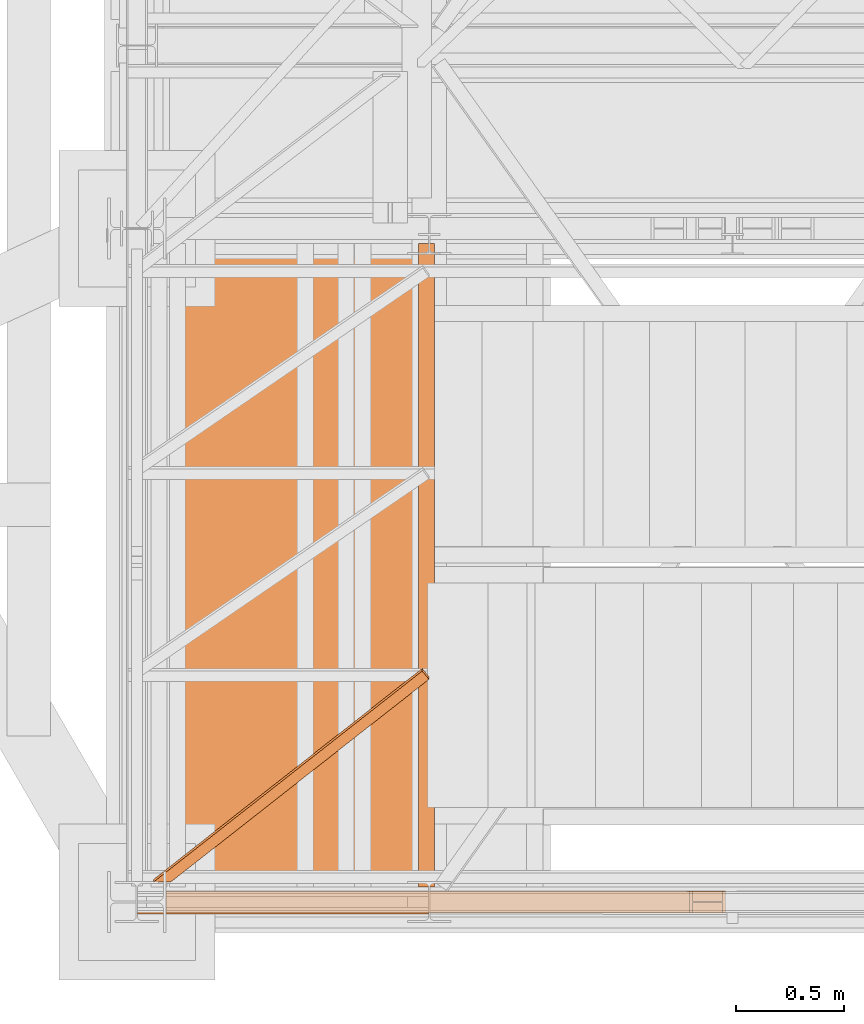
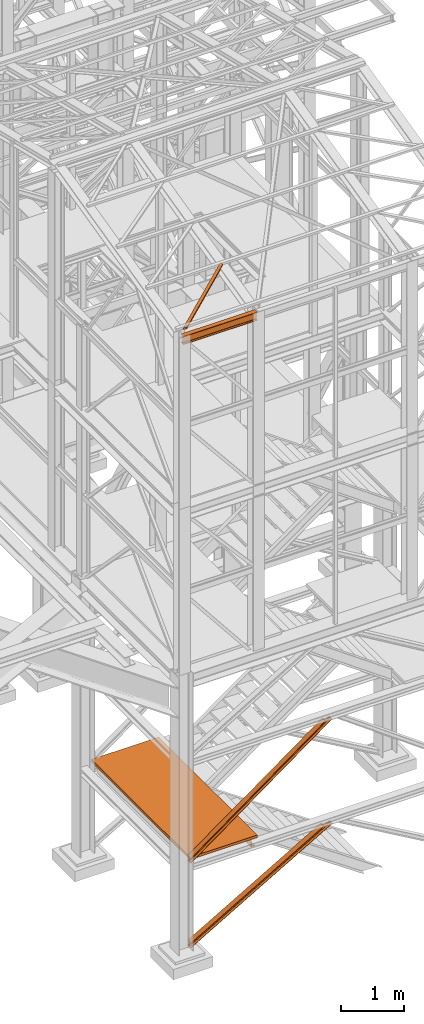
# One storey, part 8 of 208: 6 proxies.
"""IFC2X3 building model written with IfcOpenShell, lengths in millimetres."""

from ifc_helpers import new_model, entity, si_unit, converted_unit, frame, origin, origin_with_axes, place, context, subcontext, project, spatial, faceted_brep, element, save


model = new_model("IFC2X3")

# Units and contexts
model_context = context("Model", 3, precision=1e-05, world=origin())
plan_context = context("Plan", 3, precision=1e-05, world=origin())
body_context = subcontext(model_context, "Body", "Model", "MODEL_VIEW")
ifc_project = project(units=[si_unit("LENGTHUNIT", "METRE", prefix="MILLI"), converted_unit("PLANEANGLEUNIT", "DEGREE", entity("IfcPlaneAngleMeasure", 0.0174532925199433), si_unit("PLANEANGLEUNIT", "RADIAN"), dimensions=[0, 0, 0, 0, 0, 0, 0]), si_unit("AREAUNIT", "SQUARE_METRE"), si_unit("VOLUMEUNIT", "CUBIC_METRE")], contexts=[model_context, plan_context])

# Building, storey
building_placement = place(None, origin())
building = spatial("IfcBuilding", under=ifc_project, at=building_placement, CompositionType="COMPLEX")
storey_placement = place(building_placement, origin_with_axes())
storey = spatial("IfcBuildingStorey", under=building, at=storey_placement, Name="Geschoss", CompositionType="ELEMENT")

# Proxies
proxy_1_placement = place(storey_placement, frame((2498.108527679629, -25102.57439001986, 1399.989998075481), z_axis=(0.0, 0.0, 1.0), x_axis=(1.0, 0.0, 0.0)))
element("IfcBuildingElementProxy", 1, at=proxy_1_placement, inside=storey, context=body_context, shape_type="Brep", body=[
    faceted_brep([(0.01000000000021828, 2970.009999403952, 200.0100029802322), (0.01000000000021828, 2970.009999403952, 0.009999999999990905), (75.01000111758731, 2970.009999403952, 0.009999999999990905), (75.01000111758731, 2970.009999403952, 2.970830926895133), (73.89400100171588, 2970.009999403952, 7.368834147453299), (69.48847269475482, 2970.009999403952, 8.95172489643096), (19.09293180167697, 2970.009999403952, 12.98336816787719), (13.35380079060815, 2970.009999403952, 14.57858962774276), (9.50015002697728, 2970.009999403952, 18.85888857603072), (8.510000461936215, 2970.009999403952, 24.44674206733703), (8.510000461936215, 2970.009999403952, 175.5732609128952), (9.50015002697728, 2970.009999403952, 181.1611144042015), (13.35380079060815, 2970.009999403952, 185.4414133524895), (19.09293180167697, 2970.009999403952, 187.036634812355), (69.48847269475482, 2970.009999403952, 191.0682780838013), (73.89400100171588, 2970.009999403952, 192.6511688327789), (75.01000111758731, 2970.009999403952, 197.0491720533371), (75.01000111758731, 2970.009999403952, 200.0100029802322), (0.01000000000021828, 2970.009999403952, 0.009999999999990905), (0.01000000000021828, 2970.009999403952, 200.0100029802322), (0.01000000000021828, 0.01000000000203727, 200.0100029802322), (0.01000000000021828, 0.01000000000203727, 0.009999999999990905), (75.01000111758731, 2970.009999403952, 0.009999999999990905), (0.01000000000021828, 2970.009999403952, 0.009999999999990905), (0.01000000000021828, 0.01000000000203727, 0.009999999999990905), (75.01000111758731, 0.01000000000203727, 0.009999999999990905), (75.01000111758731, 2970.009999403952, 2.970830926895133), (75.01000111758731, 2970.009999403952, 0.009999999999990905), (75.01000111758731, 0.01000000000203727, 0.009999999999990905), (75.01000111758731, 0.01000000000203727, 2.970830926895133), (73.89400100171588, 2970.009999403952, 7.368834147453299), (75.01000111758731, 2970.009999403952, 2.970830926895133), (75.01000111758731, 0.01000000000203727, 2.970830926895133), (73.89400100171588, 0.01000000000203727, 7.368834147453299), (69.48847269475482, 2970.009999403952, 8.95172489643096), (73.89400100171588, 2970.009999403952, 7.368834147453299), (73.89400100171588, 0.01000000000203727, 7.368834147453299), (69.48847269475482, 0.01000000000203727, 8.95172489643096), (19.09293180167697, 2970.009999403952, 12.98336816787719), (69.48847269475482, 2970.009999403952, 8.95172489643096), (69.48847269475482, 0.01000000000203727, 8.95172489643096), (19.09293180167697, 0.01000000000203727, 12.98336816787719), (13.35380079060815, 2970.009999403952, 14.57858962774276), (19.09293180167697, 2970.009999403952, 12.98336816787719), (19.09293180167697, 0.01000000000203727, 12.98336816787719), (13.35380079060815, 0.01000000000203727, 14.57858962774276), (9.50015002697728, 2970.009999403952, 18.85888857603072), (13.35380079060815, 2970.009999403952, 14.57858962774276), (13.35380079060815, 0.01000000000203727, 14.57858962774276), (9.50015002697728, 0.01000000000203727, 18.85888857603072), (8.510000461936215, 2970.009999403952, 24.44674206733703), (9.50015002697728, 2970.009999403952, 18.85888857603072), (9.50015002697728, 0.01000000000203727, 18.85888857603072), (8.510000461936215, 0.01000000000203727, 24.44674206733703), (8.510000461936215, 2970.009999403952, 175.5732609128952), (8.510000461936215, 2970.009999403952, 24.44674206733703), (8.510000461936215, 0.01000000000203727, 24.44674206733703), (8.510000461936215, 0.01000000000203727, 175.5732609128952), (9.50015002697728, 2970.009999403952, 181.1611144042015), (8.510000461936215, 2970.009999403952, 175.5732609128952), (8.510000461936215, 0.01000000000203727, 175.5732609128952), (9.50015002697728, 0.01000000000203727, 181.1611144042015), (13.35380079060815, 2970.009999403952, 185.4414133524895), (9.50015002697728, 2970.009999403952, 181.1611144042015), (9.50015002697728, 0.01000000000203727, 181.1611144042015), (13.35380079060815, 0.01000000000203727, 185.4414133524895), (19.09293180167697, 2970.009999403952, 187.036634812355), (13.35380079060815, 2970.009999403952, 185.4414133524895), (13.35380079060815, 0.01000000000203727, 185.4414133524895), (19.09293180167697, 0.01000000000203727, 187.036634812355), (69.48847269475482, 2970.009999403952, 191.0682780838013), (19.09293180167697, 2970.009999403952, 187.036634812355), (19.09293180167697, 0.01000000000203727, 187.036634812355), (69.48847269475482, 0.01000000000203727, 191.0682780838013), (73.89400100171588, 2970.009999403952, 192.6511688327789), (69.48847269475482, 2970.009999403952, 191.0682780838013), (69.48847269475482, 0.01000000000203727, 191.0682780838013), (73.89400100171588, 0.01000000000203727, 192.6511688327789), (75.01000111758731, 2970.009999403952, 197.0491720533371), (73.89400100171588, 2970.009999403952, 192.6511688327789), (73.89400100171588, 0.01000000000203727, 192.6511688327789), (75.01000111758731, 0.01000000000203727, 197.0491720533371), (75.01000111758731, 2970.009999403952, 200.0100029802322), (75.01000111758731, 2970.009999403952, 197.0491720533371), (75.01000111758731, 0.01000000000203727, 197.0491720533371), (75.01000111758731, 0.01000000000203727, 200.0100029802322), (0.01000000000021828, 2970.009999403952, 200.0100029802322), (75.01000111758731, 2970.009999403952, 200.0100029802322), (75.01000111758731, 0.01000000000203727, 200.0100029802322), (0.01000000000021828, 0.01000000000203727, 200.0100029802322), (0.01000000000021828, 0.01000000000203727, 200.0100029802322), (75.01000111758731, 0.01000000000203727, 200.0100029802322), (75.01000111758731, 0.01000000000203727, 197.0491720533371), (73.89400100171588, 0.01000000000203727, 192.6511688327789), (69.48847269475482, 0.01000000000203727, 191.0682780838013), (19.09293180167697, 0.01000000000203727, 187.036634812355), (13.35380079060815, 0.01000000000203727, 185.4414133524895), (9.50015002697728, 0.01000000000203727, 181.1611144042015), (8.510000461936215, 0.01000000000203727, 175.5732609128952), (8.510000461936215, 0.01000000000203727, 24.44674206733703), (9.50015002697728, 0.01000000000203727, 18.85888857603072), (13.35380079060815, 0.01000000000203727, 14.57858962774276), (19.09293180167697, 0.01000000000203727, 12.98336816787719), (69.48847269475482, 0.01000000000203727, 8.95172489643096), (73.89400100171588, 0.01000000000203727, 7.368834147453299), (75.01000111758731, 0.01000000000203727, 2.970830926895133), (75.01000111758731, 0.01000000000203727, 0.009999999999990905), (0.01000000000021828, 0.01000000000203727, 0.009999999999990905)], [[[0, 1, 2, 3, 4, 5, 6, 7, 8, 9, 10, 11, 12, 13, 14, 15, 16, 17]], [[18, 19, 20, 21]], [[22, 23, 24, 25]], [[26, 27, 28, 29]], [[30, 31, 32, 33]], [[34, 35, 36, 37]], [[38, 39, 40, 41]], [[42, 43, 44, 45]], [[46, 47, 48, 49]], [[50, 51, 52, 53]], [[54, 55, 56, 57]], [[58, 59, 60, 61]], [[62, 63, 64, 65]], [[66, 67, 68, 69]], [[70, 71, 72, 73]], [[74, 75, 76, 77]], [[78, 79, 80, 81]], [[82, 83, 84, 85]], [[86, 87, 88, 89]], [[90, 91, 92, 93, 94, 95, 96, 97, 98, 99, 100, 101, 102, 103, 104, 105, 106, 107]]], orient=[[False], [False], [False], [False], [False], [False], [False], [False], [False], [False], [False], [False], [False], [False], [False], [False], [False], [False], [False], [False]]),
])
proxy_2_placement = place(storey_placement, frame((1347.770835871715, -25172.57439031789, 1599.990001055713), z_axis=(0.0, 0.0, 1.0), x_axis=(1.0, 0.0, 0.0)))
element("IfcBuildingElementProxy", 2, at=proxy_2_placement, inside=storey, context=body_context, shape_type="Brep", body=[
    faceted_brep([(0.009999999999990905, 0.01000000000203727, 0.009999999999990905), (1225.347692925502, 0.01000000000203727, 0.009999999999990905), (1225.347692925502, 3110.009999999998, 0.009999999999990905), (0.009999999999990905, 3110.009999999998, 0.009999999999990905), (1225.347692925502, 0.01000000000203727, 50.00999999999999), (0.009999999999990905, 0.01000000000203727, 50.00999999999999), (0.009999999999990905, 3110.009999999998, 50.00999999999999), (1225.347692925502, 3110.009999999998, 50.00999999999999), (1225.347692925502, 0.01000000000203727, 0.009999999999990905), (0.009999999999990905, 0.01000000000203727, 0.009999999999990905), (0.009999999999990905, 0.01000000000203727, 50.00999999999999), (1225.347692925502, 0.01000000000203727, 50.00999999999999), (1225.347692925502, 3110.009999999998, 0.009999999999990905), (1225.347692925502, 0.01000000000203727, 0.009999999999990905), (1225.347692925502, 0.01000000000203727, 50.00999999999999), (1225.347692925502, 3110.009999999998, 50.00999999999999), (0.009999999999990905, 3110.009999999998, 0.009999999999990905), (1225.347692925502, 3110.009999999998, 0.009999999999990905), (1225.347692925502, 3110.009999999998, 50.00999999999999), (0.009999999999990905, 3110.009999999998, 50.00999999999999), (0.009999999999990905, 0.01000000000203727, 0.009999999999990905), (0.009999999999990905, 3110.009999999998, 0.009999999999990905), (0.009999999999990905, 3110.009999999998, 50.00999999999999), (0.009999999999990905, 0.01000000000203727, 50.00999999999999)], [[[0, 1, 2, 3]], [[4, 5, 6, 7]], [[8, 9, 10, 11]], [[12, 13, 14, 15]], [[16, 17, 18, 19]], [[20, 21, 22, 23]]], orient=[[False], [False], [False], [False], [False], [False]]),
])
proxy_3_placement = place(storey_placement, frame((1201.504968595714, -25228.83222711344, 11599.98999433756), z_axis=(0.0, 0.0, 1.0), x_axis=(1.0, 0.0, 0.0)))
element("IfcBuildingElementProxy", 3, at=proxy_3_placement, inside=storey, context=body_context, shape_type="Brep", body=[
    faceted_brep([(1343.509999865891, 82.0100022649749, 0.01000000000021828), (1343.509999865891, 82.0100022649749, 7.409998605251531), (0.009999999999990905, 82.25026703788535, 7.409998605251531), (0.009999999999990905, 82.25026703788535, 0.01000000000021828), (1343.509999865892, 0.00999999999839929, 0.01000000000203727), (1343.509999865891, 82.0100022649749, 0.01000000000021828), (0.009999999999990905, 82.25026703788535, 0.01000000000021828), (0.009999999999990905, 0.2502647729088494, 0.01000000000021828), (1343.509999865891, 0.00999999999839929, 7.409998605251531), (1343.509999865892, 0.00999999999839929, 0.01000000000203727), (0.009999999999990905, 0.2502647729088494, 0.01000000000021828), (0.009999999999990905, 0.2502647729088494, 7.409998605251531), (1343.509999865891, 29.51000017881233, 7.409998605251531), (1343.509999865891, 0.00999999999839929, 7.409998605251531), (0.009999999999990905, 0.2502647729088494, 7.409998605251531), (0.009999999999990905, 29.75026495172278, 7.409998605251531), (1343.50999986589, 34.16790572762329, 8.342274854183415), (1343.509999865891, 29.51000017881233, 7.409998605251531), (0.009999999999990905, 29.75026495172278, 7.409998605251531), (0.009999999999990905, 34.40817050053374, 8.342274854183415), (1343.509999865891, 37.57772680207927, 11.75210011959098), (1343.50999986589, 34.16790572762329, 8.342274854183415), (0.009999999999990905, 34.40817050053374, 8.342274854183415), (0.009999999999990905, 37.81799157498972, 11.75210011959098), (1343.509999865891, 38.51000095553536, 16.41000194311164), (1343.509999865891, 37.57772680207927, 11.75210011959098), (0.009999999999990905, 37.81799157498972, 11.75210011959098), (0.009999999999990905, 38.75026572844581, 16.41000194311164), (1343.509999865891, 38.51000095553536, 143.6100093817695), (1343.509999865891, 38.51000095553536, 16.41000194311164), (0.009999999999990905, 38.75026572844581, 16.41000194311164), (0.009999999999990905, 38.75026572844581, 143.6100093817713), (1343.509999865891, 37.57772680207927, 148.267911205292), (1343.509999865891, 38.51000095553536, 143.6100093817695), (0.009999999999990905, 38.75026572844581, 143.6100093817713), (0.009999999999990905, 37.81799157498972, 148.267911205292), (1343.509999865891, 34.16790572762329, 151.6777364706995), (1343.509999865891, 37.57772680207927, 148.267911205292), (0.009999999999990905, 37.81799157498972, 148.267911205292), (0.009999999999990905, 34.40817050053374, 151.6777364706995), (1343.509999865891, 29.51000017881233, 152.6100127196314), (1343.509999865891, 34.16790572762329, 151.6777364706995), (0.009999999999990905, 34.40817050053374, 151.6777364706995), (0.009999999999990905, 29.75026495172278, 152.6100127196314), (1343.509999865891, 0.00999999999839929, 152.6100127196314), (1343.509999865891, 29.51000017881233, 152.6100127196314), (0.009999999999990905, 29.75026495172278, 152.6100127196314), (0.009999999999990905, 0.2502647729088494, 152.6100127196314), (1343.509999865891, 0.00999999999839929, 160.0100113248827), (1343.509999865891, 0.00999999999839929, 152.6100127196314), (0.009999999999990905, 0.2502647729088494, 152.6100127196314), (0.009999999999990905, 0.2502647729088494, 160.0100113248827), (1343.509999865891, 82.0100022649749, 160.0100113248827), (1343.509999865891, 0.00999999999839929, 160.0100113248827), (0.009999999999990905, 0.2502647729088494, 160.0100113248827), (0.009999999999990905, 82.25026703788535, 160.0100113248827), (1343.509999865891, 82.0100022649749, 152.6100127196314), (1343.509999865891, 82.0100022649749, 160.0100113248827), (0.009999999999990905, 82.25026703788535, 160.0100113248827), (0.009999999999990905, 82.25026703788535, 152.6100127196314), (1343.509999865891, 52.51000208616097, 152.6100127196314), (1343.509999865891, 82.0100022649749, 152.6100127196314), (0.009999999999990905, 82.25026703788535, 152.6100127196314), (0.009999999999990905, 52.75026685907142, 152.6100127196314), (1343.509999865891, 47.85209653735001, 151.6777364706995), (1343.509999865891, 52.51000208616097, 152.6100127196314), (0.009999999999990905, 52.75026685907142, 152.6100127196314), (0.009999999999990905, 48.09236131026046, 151.6777364706995), (1343.509999865891, 44.44227546289403, 148.267911205292), (1343.509999865891, 47.85209653735001, 151.6777364706995), (0.009999999999990905, 48.09236131026046, 151.6777364706995), (0.009999999999990905, 44.68254023580448, 148.267911205292), (1343.509999865891, 43.51000130943794, 143.6100093817695), (1343.509999865891, 44.44227546289403, 148.267911205292), (0.009999999999990905, 44.68254023580448, 148.267911205292), (0.009999999999990905, 43.75026608234839, 143.6100093817713), (1343.509999865891, 43.51000130943794, 16.41000194311164), (1343.509999865891, 43.51000130943794, 143.6100093817695), (0.009999999999990905, 43.75026608234839, 143.6100093817713), (0.009999999999990905, 43.75026608234839, 16.41000194311164), (1343.509999865891, 44.44227546289403, 11.7521001195928), (1343.509999865891, 43.51000130943794, 16.41000194311164), (0.009999999999990905, 43.75026608234839, 16.41000194311164), (0.009999999999990905, 44.68254023580448, 11.75210011959098), (1343.509999865891, 47.85209653735001, 8.342274854183415), (1343.509999865891, 44.44227546289403, 11.7521001195928), (0.009999999999990905, 44.68254023580448, 11.75210011959098), (0.009999999999990905, 48.09236131026046, 8.342274854183415), (1343.509999865891, 52.51000208616097, 7.409998605251531), (1343.509999865891, 47.85209653735001, 8.342274854183415), (0.009999999999990905, 48.09236131026046, 8.342274854183415), (0.009999999999990905, 52.75026685907142, 7.409998605251531), (1343.509999865891, 82.0100022649749, 7.409998605251531), (1343.509999865891, 52.51000208616097, 7.409998605251531), (0.009999999999990905, 52.75026685907142, 7.409998605251531), (0.009999999999990905, 82.25026703788535, 7.409998605251531), (0.009999999999990905, 82.25026703788535, 7.409998605251531), (0.009999999999990905, 52.75026685907142, 7.409998605251531), (0.009999999999990905, 48.09236131026046, 8.342274854183415), (0.009999999999990905, 44.68254023580448, 11.75210011959098), (0.009999999999990905, 43.75026608234839, 16.41000194311164), (0.009999999999990905, 43.75026608234839, 143.6100093817713), (0.009999999999990905, 44.68254023580448, 148.267911205292), (0.009999999999990905, 48.09236131026046, 151.6777364706995), (0.009999999999990905, 52.75026685907142, 152.6100127196314), (0.009999999999990905, 82.25026703788535, 152.6100127196314), (0.009999999999990905, 82.25026703788535, 160.0100113248827), (0.009999999999990905, 0.2502647729088494, 160.0100113248827), (0.009999999999990905, 0.2502647729088494, 152.6100127196314), (0.009999999999990905, 29.75026495172278, 152.6100127196314), (0.009999999999990905, 34.40817050053374, 151.6777364706995), (0.009999999999990905, 37.81799157498972, 148.267911205292), (0.009999999999990905, 38.75026572844581, 143.6100093817713), (0.009999999999990905, 38.75026572844581, 16.41000194311164), (0.009999999999990905, 37.81799157498972, 11.75210011959098), (0.009999999999990905, 34.40817050053374, 8.342274854183415), (0.009999999999990905, 29.75026495172278, 7.409998605251531), (0.009999999999990905, 0.2502647729088494, 7.409998605251531), (0.009999999999990905, 0.2502647729088494, 0.01000000000021828), (0.009999999999990905, 82.25026703788535, 0.01000000000021828), (1343.509999865891, 82.0100022649749, 0.01000000000021828), (1343.509999865892, 0.00999999999839929, 0.01000000000203727), (1343.509999865891, 0.00999999999839929, 7.409998605251531), (1343.509999865891, 29.51000017881233, 7.409998605251531), (1343.50999986589, 34.16790572762329, 8.342274854183415), (1343.509999865891, 37.57772680207927, 11.75210011959098), (1343.509999865891, 38.51000095553536, 16.41000194311164), (1343.509999865891, 38.51000095553536, 143.6100093817695), (1343.509999865891, 37.57772680207927, 148.267911205292), (1343.509999865891, 34.16790572762329, 151.6777364706995), (1343.509999865891, 29.51000017881233, 152.6100127196314), (1343.509999865891, 0.00999999999839929, 152.6100127196314), (1343.509999865891, 0.00999999999839929, 160.0100113248827), (1343.509999865891, 82.0100022649749, 160.0100113248827), (1343.509999865891, 82.0100022649749, 152.6100127196314), (1343.509999865891, 52.51000208616097, 152.6100127196314), (1343.509999865891, 47.85209653735001, 151.6777364706995), (1343.509999865891, 44.44227546289403, 148.267911205292), (1343.509999865891, 43.51000130943794, 143.6100093817695), (1343.509999865891, 43.51000130943794, 16.41000194311164), (1343.509999865891, 44.44227546289403, 11.7521001195928), (1343.509999865891, 47.85209653735001, 8.342274854183415), (1343.509999865891, 52.51000208616097, 7.409998605251531), (1343.509999865891, 82.0100022649749, 7.409998605251531)], [[[0, 1, 2, 3]], [[4, 5, 6, 7]], [[8, 9, 10, 11]], [[12, 13, 14, 15]], [[16, 17, 18, 19]], [[20, 21, 22, 23]], [[24, 25, 26, 27]], [[28, 29, 30, 31]], [[32, 33, 34, 35]], [[36, 37, 38, 39]], [[40, 41, 42, 43]], [[44, 45, 46, 47]], [[48, 49, 50, 51]], [[52, 53, 54, 55]], [[56, 57, 58, 59]], [[60, 61, 62, 63]], [[64, 65, 66, 67]], [[68, 69, 70, 71]], [[72, 73, 74, 75]], [[76, 77, 78, 79]], [[80, 81, 82, 83]], [[84, 85, 86, 87]], [[88, 89, 90, 91]], [[92, 93, 94, 95]], [[96, 97, 98, 99, 100, 101, 102, 103, 104, 105, 106, 107, 108, 109, 110, 111, 112, 113, 114, 115, 116, 117, 118, 119]], [[120, 121, 122, 123, 124, 125, 126, 127, 128, 129, 130, 131, 132, 133, 134, 135, 136, 137, 138, 139, 140, 141, 142, 143]]], orient=[[False], [False], [False], [False], [False], [False], [False], [False], [False], [False], [False], [False], [False], [False], [False], [False], [False], [False], [False], [False], [False], [False], [False], [False], [False], [False]]),
])
proxy_4_placement = place(storey_placement, frame((1333.254973893079, -25222.57439031789, 1566.490000221248), z_axis=(0.0, 0.0, 1.0), x_axis=(1.0, 0.0, 0.0)))
element("IfcBuildingElementProxy", 4, at=proxy_4_placement, inside=storey, context=body_context, shape_type="Brep", body=[
    faceted_brep([(0.009999999999990905, 0.00999999999839929, 88.00999999999999), (0.009999999999990905, 47.5099999999984, 88.00999999999999), (0.009999999999990905, 47.5099999999984, 8.009999999999991), (0.009999999999990905, 0.00999999999839929, 8.009999999999991), (0.009999999999990905, 0.00999999999839929, 0.009999999999990905), (0.009999999999990905, 100.0099999999984, 0.009999999999990905), (0.009999999999990905, 100.0099999999984, 8.009999999999991), (0.009999999999990905, 52.5099999999984, 8.009999999999991), (0.009999999999990905, 52.5099999999984, 88.00999999999999), (0.009999999999990905, 100.0099999999984, 88.00999999999999), (0.009999999999990905, 100.0099999999984, 96.00999999999999), (0.009999999999990905, 0.00999999999839929, 96.00999999999999), (0.009999999999990905, 0.00999999999839929, 96.00999999999999), (2446.533171438392, 0.01000000000567525, 1881.009998688699), (2457.497981178383, 0.01000000000567525, 1881.009998688699), (0.009999999999990905, 0.00999999999839929, 88.00999999999999), (0.009999999999990905, 100.0099999999984, 96.00999999999999), (2446.533171438393, 100.0100000000057, 1881.009998688699), (2446.533171438392, 0.01000000000567525, 1881.009998688699), (0.009999999999990905, 0.00999999999839929, 96.00999999999999), (0.009999999999990905, 100.0099999999984, 88.00999999999999), (2457.497981178383, 100.010000000002, 1881.009998688699), (2446.533171438393, 100.0100000000057, 1881.009998688699), (0.009999999999990905, 100.0099999999984, 96.00999999999999), (0.009999999999990905, 52.5099999999984, 88.00999999999999), (2457.497981178384, 52.51000000000568, 1881.0099986887), (2457.497981178383, 100.010000000002, 1881.009998688699), (0.009999999999990905, 100.0099999999984, 88.00999999999999), (0.009999999999990905, 52.5099999999984, 8.009999999999991), (2567.146078578301, 52.51000000000568, 1881.009998688699), (2457.497981178384, 52.51000000000568, 1881.0099986887), (0.009999999999990905, 52.5099999999984, 88.00999999999999), (0.009999999999990905, 100.0099999999984, 8.009999999999991), (2567.146078578302, 100.0100000000057, 1881.009998688699), (2567.146078578301, 52.51000000000568, 1881.009998688699), (0.009999999999990905, 52.5099999999984, 8.009999999999991), (0.009999999999990905, 100.0099999999984, 0.009999999999990905), (2578.110888318293, 100.0100000000057, 1881.009998688699), (2567.146078578302, 100.0100000000057, 1881.009998688699), (0.009999999999990905, 100.0099999999984, 8.009999999999991), (0.009999999999990905, 0.00999999999839929, 0.009999999999990905), (2578.110888318294, 0.01000000000567525, 1881.009998688699), (2578.110888318293, 100.0100000000057, 1881.009998688699), (0.009999999999990905, 100.0099999999984, 0.009999999999990905), (0.009999999999990905, 0.00999999999839929, 8.009999999999991), (2567.146078578301, 0.01000000000567525, 1881.009998688699), (2578.110888318294, 0.01000000000567525, 1881.009998688699), (0.009999999999990905, 0.00999999999839929, 0.009999999999990905), (0.009999999999990905, 47.5099999999984, 8.009999999999991), (2567.146078578302, 47.51000000000568, 1881.009998688699), (2567.146078578301, 0.01000000000567525, 1881.009998688699), (0.009999999999990905, 0.00999999999839929, 8.009999999999991), (0.009999999999990905, 47.5099999999984, 88.00999999999999), (2457.497981178383, 47.51000000000568, 1881.009998688699), (2567.146078578302, 47.51000000000568, 1881.009998688699), (0.009999999999990905, 47.5099999999984, 8.009999999999991), (0.009999999999990905, 0.00999999999839929, 88.00999999999999), (2457.497981178383, 0.01000000000567525, 1881.009998688699), (2457.497981178383, 47.51000000000568, 1881.009998688699), (0.009999999999990905, 47.5099999999984, 88.00999999999999), (2446.533171438392, 0.01000000000567525, 1881.009998688699), (2446.533171438393, 100.0100000000057, 1881.009998688699), (2457.497981178383, 100.010000000002, 1881.009998688699), (2457.497981178384, 52.51000000000568, 1881.0099986887), (2567.146078578301, 52.51000000000568, 1881.009998688699), (2567.146078578302, 100.0100000000057, 1881.009998688699), (2578.110888318293, 100.0100000000057, 1881.009998688699), (2578.110888318294, 0.01000000000567525, 1881.009998688699), (2567.146078578301, 0.01000000000567525, 1881.009998688699), (2567.146078578302, 47.51000000000568, 1881.009998688699), (2457.497981178383, 47.51000000000568, 1881.009998688699), (2457.497981178383, 0.01000000000567525, 1881.009998688699)], [[[0, 1, 2, 3, 4, 5, 6, 7, 8, 9, 10, 11]], [[12, 13, 14, 15]], [[16, 17, 18, 19]], [[20, 21, 22, 23]], [[24, 25, 26, 27]], [[28, 29, 30, 31]], [[32, 33, 34, 35]], [[36, 37, 38, 39]], [[40, 41, 42, 43]], [[44, 45, 46, 47]], [[48, 49, 50, 51]], [[52, 53, 54, 55]], [[56, 57, 58, 59]], [[60, 61, 62, 63, 64, 65, 66, 67, 68, 69, 70, 71]]], orient=[[False], [False], [False], [False], [False], [False], [False], [False], [False], [False], [False], [False], [False], [False]]),
])
proxy_5_placement = place(storey_placement, frame((1333.25497389308, -25222.57439031789, -65.00999999999999), z_axis=(0.0, 0.0, 1.0), x_axis=(1.0, 0.0, 0.0)))
element("IfcBuildingElementProxy", 5, at=proxy_5_placement, inside=storey, context=body_context, shape_type="Brep", body=[
    faceted_brep([(0.009999999999990905, 0.00999999999839929, 88.00999999999999), (0.009999999999990905, 47.5099999999984, 88.00999999999999), (0.009999999999990905, 47.5099999999984, 8.009999999999991), (0.009999999999990905, 0.00999999999839929, 8.009999999999991), (0.009999999999990905, 0.00999999999839929, 0.009999999999990905), (0.009999999999990905, 100.0099999999984, 0.009999999999990905), (0.009999999999990905, 100.0099999999984, 8.009999999999991), (0.009999999999990905, 52.5099999999984, 8.009999999999991), (0.009999999999990905, 52.5099999999984, 88.00999999999999), (0.009999999999990905, 100.0099999999984, 88.00999999999999), (0.009999999999990905, 100.0099999999984, 96.00999999999999), (0.009999999999990905, 0.00999999999839929, 96.00999999999999), (0.009999999999990905, 0.00999999999839929, 96.00999999999999), (2417.635238083693, 0.01000000000567525, 1498.509998909946), (2431.425613784015, 0.01000000000203727, 1498.509998909946), (0.009999999999990905, 0.00999999999839929, 88.00999999999999), (0.009999999999990905, 100.0099999999984, 96.00999999999999), (2417.635238083693, 100.010000000002, 1498.509998909947), (2417.635238083693, 0.01000000000567525, 1498.509998909946), (0.009999999999990905, 0.00999999999839929, 96.00999999999999), (0.009999999999990905, 100.0099999999984, 88.00999999999999), (2431.425613784015, 100.0100000000057, 1498.509998909946), (2417.635238083693, 100.010000000002, 1498.509998909947), (0.009999999999990905, 100.0099999999984, 96.00999999999999), (0.009999999999990905, 52.5099999999984, 88.00999999999999), (2431.425613784016, 52.51000000000204, 1498.509998909946), (2431.425613784015, 100.0100000000057, 1498.509998909946), (0.009999999999990905, 100.0099999999984, 88.00999999999999), (0.009999999999990905, 52.5099999999984, 8.009999999999991), (2569.329370787236, 52.51000000000568, 1498.509998909946), (2431.425613784016, 52.51000000000204, 1498.509998909946), (0.009999999999990905, 52.5099999999984, 88.00999999999999), (0.009999999999990905, 100.0099999999984, 8.009999999999991), (2569.329370787237, 100.010000000002, 1498.509998909947), (2569.329370787236, 52.51000000000568, 1498.509998909946), (0.009999999999990905, 52.5099999999984, 8.009999999999991), (0.009999999999990905, 100.0099999999984, 0.009999999999990905), (2583.119746487559, 100.0100000000057, 1498.509998909946), (2569.329370787237, 100.010000000002, 1498.509998909947), (0.009999999999990905, 100.0099999999984, 8.009999999999991), (0.009999999999990905, 0.00999999999839929, 0.009999999999990905), (2583.11974648756, 0.01000000000567525, 1498.509998909947), (2583.119746487559, 100.0100000000057, 1498.509998909946), (0.009999999999990905, 100.0099999999984, 0.009999999999990905), (0.009999999999990905, 0.00999999999839929, 8.009999999999991), (2569.329370787236, 0.01000000000567525, 1498.509998909946), (2583.11974648756, 0.01000000000567525, 1498.509998909947), (0.009999999999990905, 0.00999999999839929, 0.009999999999990905), (0.009999999999990905, 47.5099999999984, 8.009999999999991), (2569.329370787237, 47.51000000000568, 1498.509998909947), (2569.329370787236, 0.01000000000567525, 1498.509998909946), (0.009999999999990905, 0.00999999999839929, 8.009999999999991), (0.009999999999990905, 47.5099999999984, 88.00999999999999), (2431.425613784015, 47.51000000000568, 1498.509998909946), (2569.329370787237, 47.51000000000568, 1498.509998909947), (0.009999999999990905, 47.5099999999984, 8.009999999999991), (0.009999999999990905, 0.00999999999839929, 88.00999999999999), (2431.425613784015, 0.01000000000203727, 1498.509998909946), (2431.425613784015, 47.51000000000568, 1498.509998909946), (0.009999999999990905, 47.5099999999984, 88.00999999999999), (2417.635238083693, 0.01000000000567525, 1498.509998909946), (2417.635238083693, 100.010000000002, 1498.509998909947), (2431.425613784015, 100.0100000000057, 1498.509998909946), (2431.425613784016, 52.51000000000204, 1498.509998909946), (2569.329370787236, 52.51000000000568, 1498.509998909946), (2569.329370787237, 100.010000000002, 1498.509998909947), (2583.119746487559, 100.0100000000057, 1498.509998909946), (2583.11974648756, 0.01000000000567525, 1498.509998909947), (2569.329370787236, 0.01000000000567525, 1498.509998909946), (2569.329370787237, 47.51000000000568, 1498.509998909947), (2431.425613784015, 47.51000000000568, 1498.509998909946), (2431.425613784015, 0.01000000000203727, 1498.509998909946)], [[[0, 1, 2, 3, 4, 5, 6, 7, 8, 9, 10, 11]], [[12, 13, 14, 15]], [[16, 17, 18, 19]], [[20, 21, 22, 23]], [[24, 25, 26, 27]], [[28, 29, 30, 31]], [[32, 33, 34, 35]], [[36, 37, 38, 39]], [[40, 41, 42, 43]], [[44, 45, 46, 47]], [[48, 49, 50, 51]], [[52, 53, 54, 55]], [[56, 57, 58, 59]], [[60, 61, 62, 63, 64, 65, 66, 67, 68, 69, 70, 71]]], orient=[[False], [False], [False], [False], [False], [False], [False], [False], [False], [False], [False], [False], [False], [False]]),
])
proxy_6_placement = place(storey_placement, frame((1274.022561992558, -25080.97715368805, 11758.07001658348), z_axis=(0.0, 0.0, 1.0), x_axis=(1.0, 0.0, 0.0)))
element("IfcBuildingElementProxy", 6, at=proxy_6_placement, inside=storey, context=body_context, shape_type="Brep", body=[
    faceted_brep([(1241.516525958019, 986.5879088895417, 236.6199846940144), (1272.939710584227, 948.7934207667204, 227.4461013569999), (1272.939710584227, 936.9993550698855, 276.0351949309552), (1241.516525958019, 974.7938431927068, 285.2090782679716), (0.01000000000317414, 11.80406569683692, 0.01000000000021828), (1241.516525958019, 986.5879088895417, 236.6199846940144), (1241.516525958019, 974.7938431927068, 285.2090782679716), (0.009999999999990905, 0.00999999999839929, 48.59909357395372), (79.56909083495407, 11.80406569683328, 0.01000000000021828), (1272.939710584227, 948.7934207667204, 227.4461013569999), (1241.516525958019, 986.5879088895417, 236.6199846940144), (0.01000000000317414, 11.80406569683692, 0.01000000000021828), (79.5690908349552, 0.00999999999839929, 48.59909357395736), (1272.939710584227, 936.9993550698855, 276.0351949309552), (1272.939710584227, 948.7934207667204, 227.4461013569999), (79.56909083495407, 11.80406569683328, 0.01000000000021828), (0.009999999999990905, 0.00999999999839929, 48.59909357395372), (1241.516525958019, 974.7938431927068, 285.2090782679716), (1272.939710584227, 936.9993550698855, 276.0351949309552), (79.5690908349552, 0.00999999999839929, 48.59909357395736), (0.01000000000317414, 11.80406569683692, 0.01000000000021828), (0.009999999999990905, 0.00999999999839929, 48.59909357395372), (79.5690908349552, 0.00999999999839929, 48.59909357395736), (79.56909083495407, 11.80406569683328, 0.01000000000021828)], [[[0, 1, 2, 3]], [[4, 5, 6, 7]], [[8, 9, 10, 11]], [[12, 13, 14, 15]], [[16, 17, 18, 19]], [[20, 21, 22, 23]]], orient=[[False], [False], [False], [False], [False], [False]]),
])

save(model, "model.ifc")
